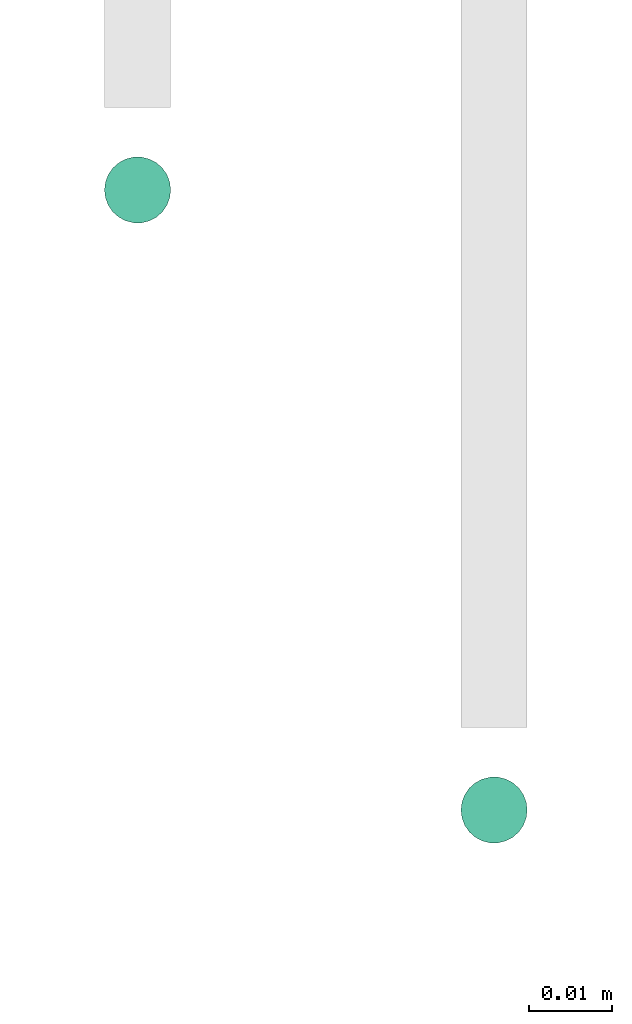
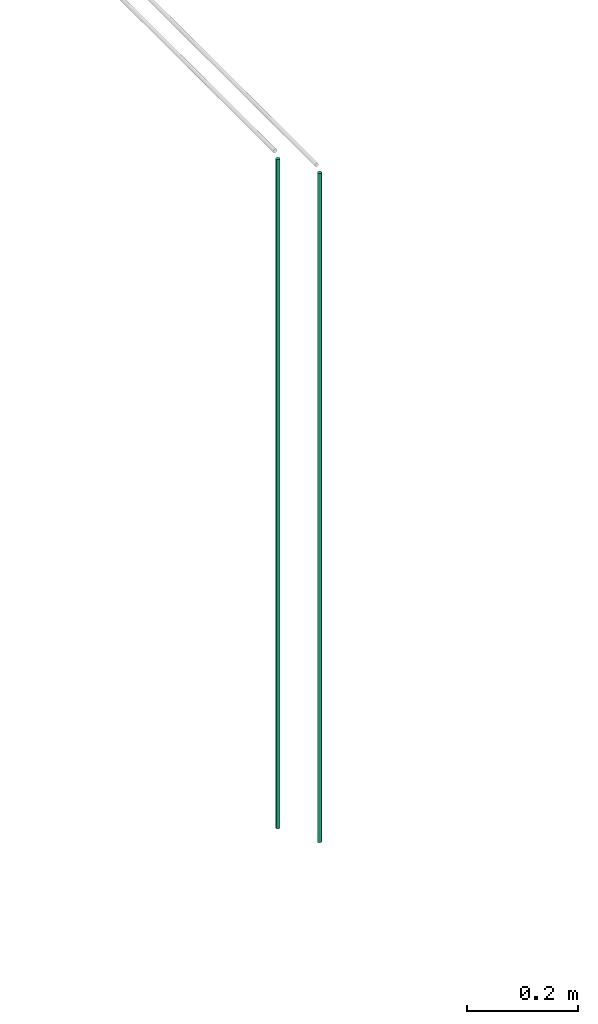
# One storey, part 7 of 89: 2 flow segments.
"""IFC2X3 building model written with IfcOpenShell, lengths in millimetres."""

from ifc_helpers import new_model, entity, si_unit, converted_unit, derived_unit, direction, frame, origin, origin_2d_with_axis, place, context, subcontext, project, spatial, circle, extrude, type_object, element, save


model = new_model("IFC2X3")

# Units and contexts
model_context = context("Model", 3, precision=0.01, world=origin(), true_north=direction((6.12303176911189e-17, 1.0)))
body_context = subcontext(model_context, "Body", "Model", "MODEL_VIEW")
ifc_project = project(units=[si_unit("LENGTHUNIT", "METRE", prefix="MILLI"), si_unit("AREAUNIT", "SQUARE_METRE"), si_unit("VOLUMEUNIT", "CUBIC_METRE"), converted_unit("PLANEANGLEUNIT", "DEGREE", entity("IfcRatioMeasure", 0.0174532925199433), si_unit("PLANEANGLEUNIT", "RADIAN"), dimensions=[0, 0, 0, 0, 0, 0, 0]), si_unit("MASSUNIT", "GRAM", prefix="KILO"), derived_unit("MASSDENSITYUNIT", [(si_unit("MASSUNIT", "GRAM", prefix="KILO"), 1), (si_unit("LENGTHUNIT", "METRE"), -3)]), derived_unit("MOMENTOFINERTIAUNIT", [(si_unit("LENGTHUNIT", "METRE"), 4)]), si_unit("TIMEUNIT", "SECOND"), si_unit("FREQUENCYUNIT", "HERTZ"), si_unit("THERMODYNAMICTEMPERATUREUNIT", "DEGREE_CELSIUS"), derived_unit("THERMALTRANSMITTANCEUNIT", [(si_unit("MASSUNIT", "GRAM", prefix="KILO"), 1), (si_unit("THERMODYNAMICTEMPERATUREUNIT", "KELVIN"), -1), (si_unit("TIMEUNIT", "SECOND"), -3)]), derived_unit("VOLUMETRICFLOWRATEUNIT", [(si_unit("LENGTHUNIT", "METRE"), 3), (si_unit("TIMEUNIT", "SECOND"), -1)]), derived_unit("MASSFLOWRATEUNIT", [(si_unit("MASSUNIT", "GRAM", prefix="KILO"), 1), (si_unit("TIMEUNIT", "SECOND"), -1)]), derived_unit("ROTATIONALFREQUENCYUNIT", [(si_unit("TIMEUNIT", "SECOND"), -1)]), si_unit("ELECTRICCURRENTUNIT", "AMPERE"), si_unit("ELECTRICVOLTAGEUNIT", "VOLT"), si_unit("POWERUNIT", "WATT"), si_unit("FORCEUNIT", "NEWTON", prefix="KILO"), si_unit("ILLUMINANCEUNIT", "LUX"), si_unit("LUMINOUSFLUXUNIT", "LUMEN"), si_unit("LUMINOUSINTENSITYUNIT", "CANDELA"), derived_unit("USERDEFINED", [(si_unit("MASSUNIT", "GRAM", prefix="KILO"), -1), (si_unit("LENGTHUNIT", "METRE"), -2), (si_unit("TIMEUNIT", "SECOND"), 3), (si_unit("LUMINOUSFLUXUNIT", "LUMEN"), 1)]), derived_unit("LINEARVELOCITYUNIT", [(si_unit("LENGTHUNIT", "METRE"), 1), (si_unit("TIMEUNIT", "SECOND"), -1)]), si_unit("PRESSUREUNIT", "PASCAL"), derived_unit("USERDEFINED", [(si_unit("LENGTHUNIT", "METRE"), -2), (si_unit("MASSUNIT", "GRAM", prefix="KILO"), 1), (si_unit("TIMEUNIT", "SECOND"), -2)]), derived_unit("LINEARFORCEUNIT", [(si_unit("MASSUNIT", "GRAM", prefix="KILO"), 1), (si_unit("LENGTHUNIT", "METRE"), 1), (si_unit("TIMEUNIT", "SECOND"), -2), (si_unit("LENGTHUNIT", "METRE"), -1)]), derived_unit("PLANARFORCEUNIT", [(si_unit("MASSUNIT", "GRAM", prefix="KILO"), 1), (si_unit("LENGTHUNIT", "METRE"), 1), (si_unit("TIMEUNIT", "SECOND"), -2), (si_unit("LENGTHUNIT", "METRE"), -2)])], contexts=[model_context])

# Site, building, storey
site_placement = place(None, frame((0.0, -0.00077364408347762, 0.0)))
site = spatial("IfcSite", under=ifc_project, at=site_placement, CompositionType="ELEMENT")
building_placement = place(site_placement, origin())
building = spatial("IfcBuilding", under=site, at=building_placement, CompositionType="ELEMENT")
storey_placement = place(building_placement, frame((0.0, 0.0, 24000.0)))
storey = spatial("IfcBuildingStorey", under=building, at=storey_placement, CompositionType="ELEMENT", Elevation=24000.0)

# Flow segments
pipe_segment_type = type_object("IfcPipeSegmentType", PredefinedType="NOTDEFINED")
for number, where in (
    (1, (41814.4237854135, 15854.4047204552, 1599.29036474498)),
    (2, (41771.3043091155, 15929.4047204552, 1599.29036474498)),
):
    element("IfcFlowSegment", number, at=place(storey_placement, frame(where)), inside=storey, type_object=pipe_segment_type, context=body_context, shape_type="SweptSolid", body=[
        extrude(circle(Radius=4.0, at=origin_2d_with_axis()), frame((5.59527223591499, 5.59527223591499, 0.0)), (0.0, 0.0, 1.0), 1465.70963525502),
    ])

save(model, "model.ifc")
